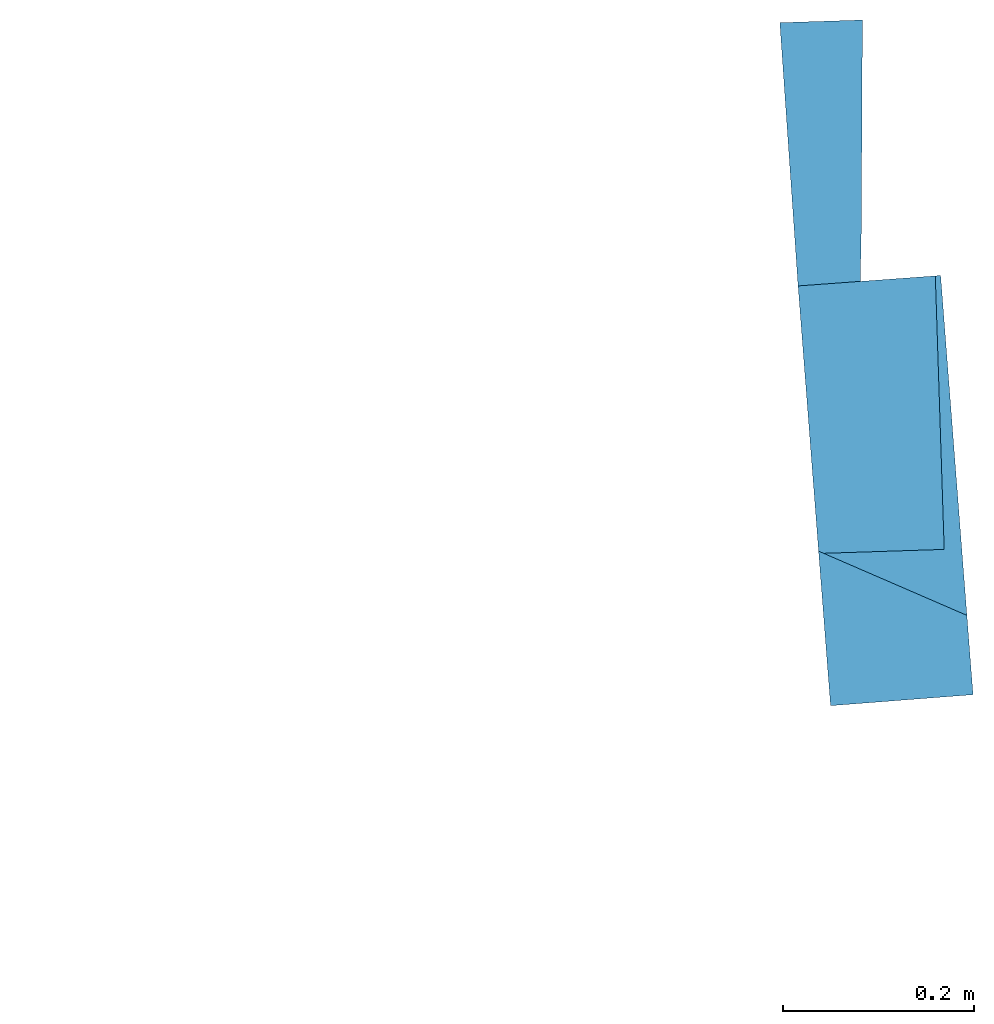
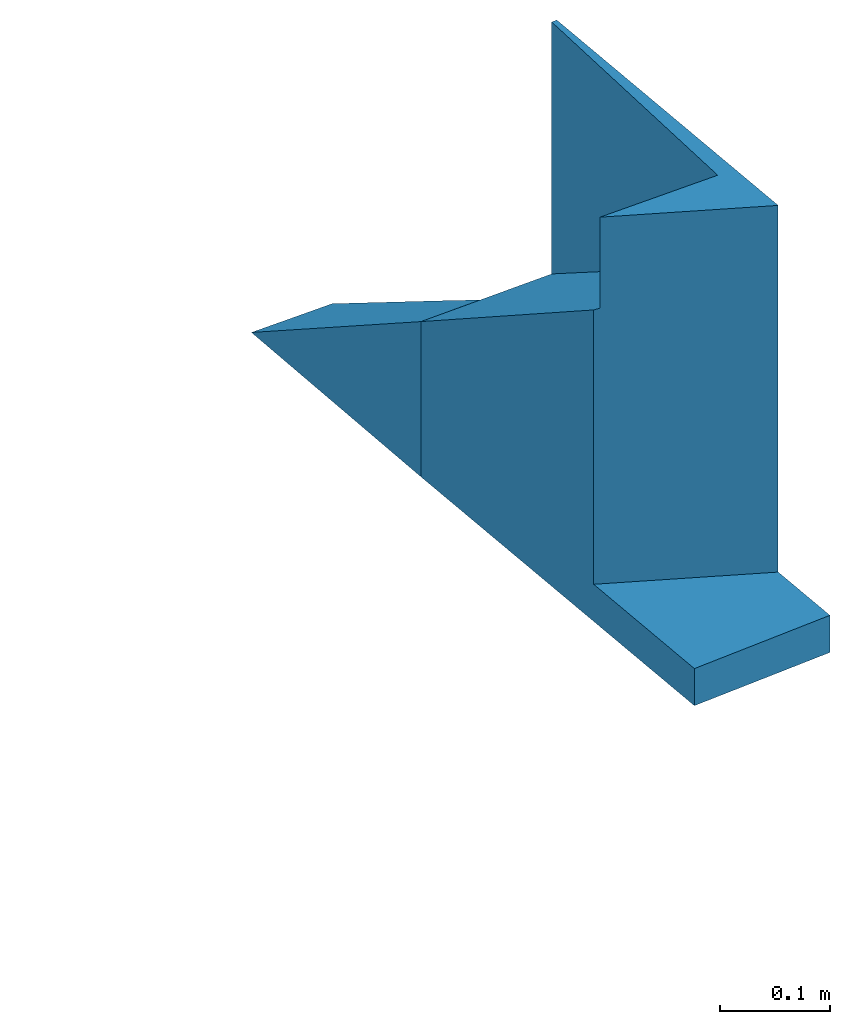
# One storey, part 1 of 2: 2 walls.
"""IFC4 building model written with IfcOpenShell, lengths in metres."""

from ifc_helpers import new_model, entity, si_unit, converted_unit, derived_unit, direction, frame, origin, place, context, subcontext, project, spatial, polygons, material, type_object, element, save


model = new_model("IFC4")

# Units and contexts
model_context = context("Model", 3, precision=1e-05, world=origin(), true_north=direction((6.123233995736766e-17, 1.0)))
body_context = subcontext(model_context, "Body", "Model", "MODEL_VIEW")
ifc_project = project(units=[si_unit("LENGTHUNIT", "METRE"), si_unit("AREAUNIT", "SQUARE_METRE"), si_unit("VOLUMEUNIT", "CUBIC_METRE"), converted_unit("PLANEANGLEUNIT", "DEGREE", entity("IfcPlaneAngleMeasure", 0.017453292519943278), si_unit("PLANEANGLEUNIT", "RADIAN"), dimensions=[0, 0, 0, 0, 0, 0, 0]), derived_unit("THERMALTRANSMITTANCEUNIT", [(si_unit("MASSUNIT", "GRAM", prefix="KILO"), 1), (si_unit("THERMODYNAMICTEMPERATUREUNIT", "KELVIN"), -1), (si_unit("TIMEUNIT", "SECOND"), -3)])], contexts=[model_context])

# Site, building, storey
site_placement = place(None, origin())
site = spatial("IfcSite", under=ifc_project, at=site_placement, CompositionType="ELEMENT")
building_placement = place(site_placement, origin())
building = spatial("IfcBuilding", under=site, at=building_placement, CompositionType="ELEMENT")
storey_placement = place(building_placement, frame((0.0, 0.0, -0.12999999999999998)))
storey = spatial("IfcBuildingStorey", under=building, at=storey_placement, Name="- 0.13 m", CompositionType="ELEMENT", Elevation=-0.12999999999999998)

# Walls
ifc_material = material(Name="Default - Muro")
wall_type = type_object("IfcWallType", Name="Muro di base:Generico", PredefinedType="STANDARD")
wall_1_placement = place(storey_placement, frame((3.9059275597100616, 8.373694364257927, 0.0), z_axis=(0.0, 0.0, 1.0), x_axis=(-0.07708457249613154, 0.9970245577131431, 0.0)))
element("IfcWall", 1, at=wall_1_placement, inside=storey, type_object=wall_type, material=ifc_material, Name="Muro di base:Generico", ObjectType="Muro di base:Generico", PredefinedType="NOTDEFINED", context=body_context, shape_type="Tessellation", body=[
    polygons([(0.0, -0.07499999999999996, 0.0), (0.4411629493967695, -0.07499999999999984, -2.7755575615628914e-17), (0.4411629493967695, -0.07499999999999984, 0.45000000000000007), (0.08345553096103053, -0.07500000000000062, 0.45000000000000007), (0.08345553096103053, -0.07500000000000062, 0.04135237977076395), (1.7763568394002505e-15, -0.07500000000000018, 0.04135237977076395), (0.44176500628036663, 0.07499999999999951, -2.7755575615628914e-17), (0.0, 0.07499999999999996, 0.0), (0.0, 0.07499999999999996, 0.04135237977076395), (0.1626749336813038, 0.07499999999999973, 0.04135237977076395), (0.1626749336813038, 0.0749999999999984, 0.3471199019462286), (0.44176500628036663, 0.07499999999999951, 0.17289925126396974), (0.4415364780017583, 0.018063117912573645, 0.0), (0.4411854851270345, -0.06938531535493808, 0.45000000000000007), (0.15433281011479494, -0.056555087218291056, 0.45000000000000007), (0.15838399725905639, 0.034019597575289606, 0.45000000000000007), (0.15998952275472433, 0.06991524014123929, 0.4500000000000002), (0.4415022694698276, 0.009540202671112774, 0.17123556152515512), (0.4411854851270345, -0.0693853153549372, 0.16922963453135678), (0.15433281011479494, -0.056555087218291056, 0.3486542854495478), (0.158567961210192, 0.03813258379245754, 0.3486542854495478), (0.15998952275472433, 0.0699152401412384, 0.34865428544954796)], [[[1, 2, 3, 4, 5, 6]], [[7, 8, 9, 10, 11, 12]], [[2, 1, 8, 7, 13]], [[4, 3, 14, 15, 16, 17]], [[8, 1, 6, 9]], [[3, 2, 13, 7, 12, 18, 19, 14]], [[20, 15, 14, 19]], [[15, 20, 21, 22, 17, 16]], [[20, 19, 18, 12, 11, 22, 21]], [[10, 5, 4, 17, 22, 11]], [[5, 10, 9, 6]]], closed=True),
])
wall_2_placement = place(storey_placement, frame((3.87191829235271, 8.813544482158832, 0.0), z_axis=(0.0, 0.0, 1.0), x_axis=(-0.06907867784852438, 0.9976112149864295, 0.0)))
element("IfcWall", 2, at=wall_2_placement, inside=storey, type_object=wall_type, material=ifc_material, Name="Muro di base:Generico", ObjectType="Muro di base:Generico", PredefinedType="NOTDEFINED", context=body_context, shape_type="Tessellation", body=[
    polygons([(0.2768827857966478, 0.07499999999999973, 1.2490009027033011e-15), (1.7763568394002505e-15, 0.07499999999999984, 1.8596235662471372e-15), (1.7763568394002505e-15, 0.07499999999999984, 0.17289925126419137), (0.000228528278579887, 0.018063117912571758, 1.8318679906315083e-15), (0.2737034691824718, -0.011660907026672995, 3.0808688933348094e-15), (0.055106291256525, 0.011433933298380938, 1.3877787807814457e-15), (0.0002627368105034833, 0.009540202671108333, 0.17123556152537378), (0.05458510432886676, 0.004671219339004162, 0.13720245527252725)], [[[1, 2, 3]], [[4, 2, 1, 5, 6]], [[2, 4, 7, 3]], [[6, 5, 8]], [[4, 6, 8, 7]], [[1, 3, 7, 8, 5]]], closed=True),
])

save(model, "model.ifc")
